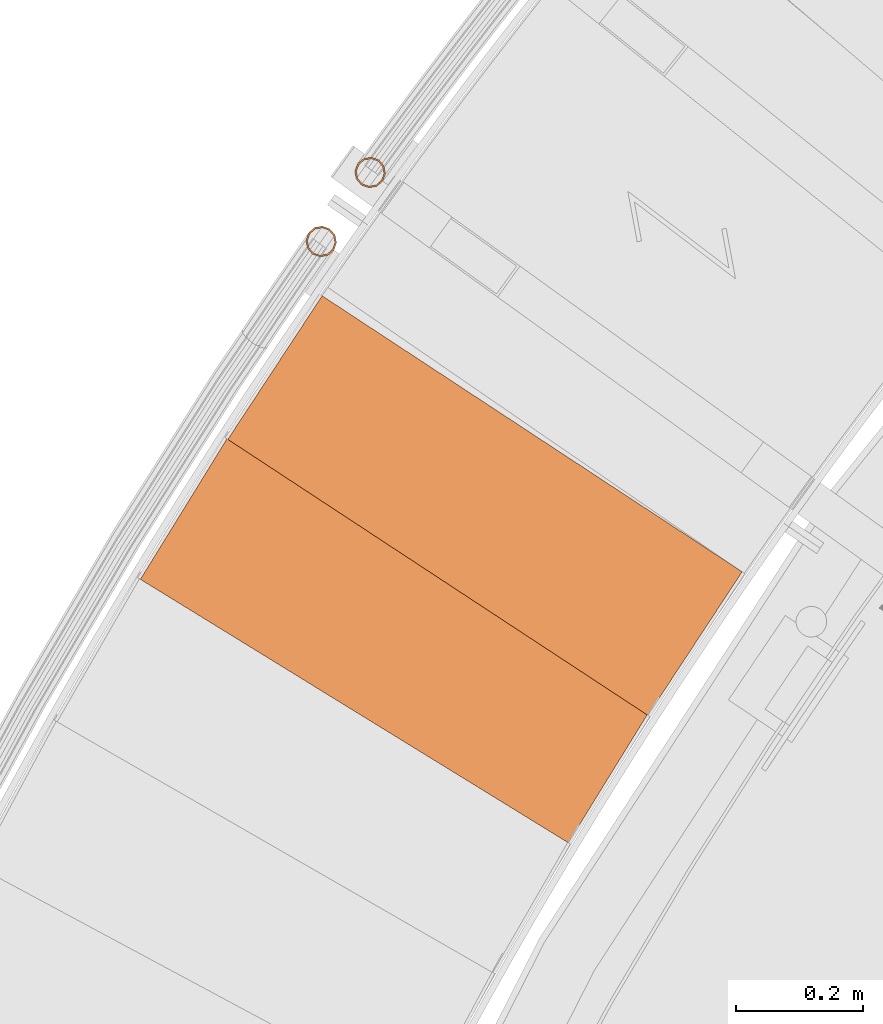
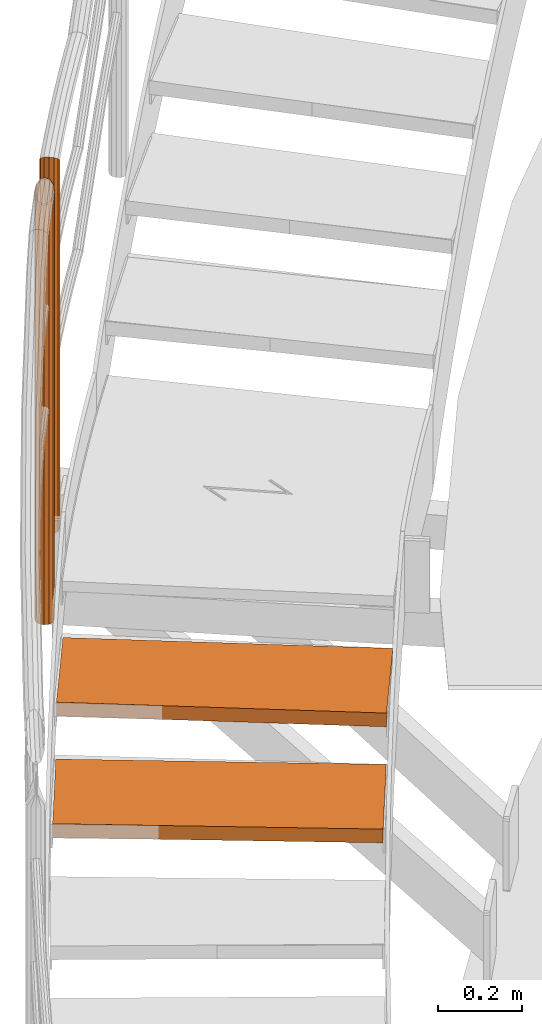
# One storey, part 30 of 126: 4 proxies.
"""IFC2X3 building model written with IfcOpenShell, lengths in millimetres."""

from ifc_helpers import new_model, si_unit, origin, origin_with_axes, place, context, project, spatial, faceted_brep, material, element, save


model = new_model("IFC2X3")

# Units and contexts
context_of_model_1 = context(None, 3, precision=0.1, world=origin())
context_of_model_2 = context(None, 3, precision=0.1, world=origin())
ifc_project = project(units=[si_unit("LENGTHUNIT", "METRE", prefix="MILLI"), si_unit("AREAUNIT", "SQUARE_METRE", prefix="CENTI"), si_unit("VOLUMEUNIT", "CUBIC_METRE", prefix="CENTI"), si_unit("MASSUNIT", "GRAM", prefix="KILO")], contexts=[context_of_model_1, context_of_model_2])

# Site, building, storey
site_placement = place(None, origin_with_axes())
site = spatial("IfcSite", under=ifc_project, at=site_placement, CompositionType="ELEMENT")
building_placement = place(site_placement, origin_with_axes())
building = spatial("IfcBuilding", under=site, at=building_placement, CompositionType="ELEMENT")
storey_placement = place(building_placement, origin_with_axes())
storey = spatial("IfcBuildingStorey", under=building, at=storey_placement, CompositionType="ELEMENT")

# Proxies
ifc_material = material(Name="S235JRG2")
proxy_1_placement = place(storey_placement, origin_with_axes())
element("IfcBuildingElementProxy", 1, at=proxy_1_placement, inside=storey, material=ifc_material, context=context_of_model_2, shape_type="Brep", body=[
    faceted_brep([(462.6859, 12561.818, 7926.89), (462.6859, 12561.818, 7966.89), (604.2286, 12791.743, 7966.89), (604.2286, 12791.743, 7926.89), (1135.4304, 12147.675, 7926.89), (1276.9731, 12377.6, 7926.89), (1276.9731, 12377.6, 7966.89), (1135.4304, 12147.675, 7966.89)], [[[0, 1, 2, 3]], [[4, 5, 6, 7]], [[0, 4, 7, 1]], [[1, 7, 6, 2]], [[2, 6, 5, 3]], [[3, 5, 4, 0]]]),
])
proxy_2_placement = place(storey_placement, origin_with_axes())
element("IfcBuildingElementProxy", 2, at=proxy_2_placement, inside=storey, material=ifc_material, context=context_of_model_2, shape_type="Brep", body=[
    faceted_brep([(600.0769, 12781.841, 8100.05), (600.0769, 12781.841, 8140.05), (748.3257, 13007.5, 8140.05), (748.3257, 13007.5, 8100.05), (1260.3402, 12348.075, 8100.05), (1408.5891, 12573.735, 8100.05), (1408.5891, 12573.735, 8140.05), (1260.3402, 12348.075, 8140.05)], [[[0, 1, 2, 3]], [[4, 5, 6, 7]], [[0, 4, 7, 1]], [[1, 7, 6, 2]], [[2, 6, 5, 3]], [[3, 5, 4, 0]]]),
])
proxy_3_placement = place(storey_placement, origin_with_axes())
element("IfcBuildingElementProxy", 3, at=proxy_3_placement, inside=storey, material=ifc_material, Name="HANDLAUF", context=context_of_model_2, shape_type="Brep", body=[
    faceted_brep([(760.3314, 13112.804, 8142.65), (748.4918, 13116.816, 8142.65), (748.4918, 13116.816, 9409.7746), (760.3314, 13112.804, 9413.3492), (768.5788, 13103.41, 9410.4852), (768.5788, 13103.41, 8142.65), (771.024, 13091.15, 9401.9499), (771.024, 13091.15, 8142.65), (767.0119, 13079.311, 9390.0304), (767.0119, 13079.311, 8142.65), (757.6175, 13071.063, 9377.9205), (757.6175, 13071.063, 8142.65), (745.358, 13068.618, 9368.8651), (745.358, 13068.618, 8142.65), (733.5184, 13072.63, 9365.2905), (733.5184, 13072.63, 8142.65), (725.271, 13082.025, 9368.1545), (725.271, 13082.025, 8142.65), (722.8258, 13094.284, 9376.6898), (722.8258, 13094.284, 8142.65), (726.8379, 13106.124, 9388.6093), (726.8379, 13106.124, 8142.65), (736.2323, 13114.371, 9400.7191), (736.2323, 13114.371, 8142.65), (737.3392, 13112.129, 8142.65), (748.3296, 13114.322, 8142.65), (748.3296, 13114.322, 9407.6571), (737.3392, 13112.129, 9399.5391), (728.9173, 13104.736, 9388.6828), (728.9173, 13104.736, 8142.65), (725.3205, 13094.122, 9377.9972), (725.3205, 13094.122, 8142.65), (727.5126, 13083.131, 9370.3455), (727.5126, 13083.131, 8142.65), (734.9062, 13074.71, 9367.778), (734.9062, 13074.71, 8142.65), (745.5202, 13071.113, 9370.9826), (745.5202, 13071.113, 8142.65), (756.5106, 13073.305, 9379.1006), (756.5106, 13073.305, 8142.65), (764.9325, 13080.698, 9389.9569), (764.9325, 13080.698, 8142.65), (768.5293, 13091.312, 9400.6425), (768.5293, 13091.312, 8142.65), (766.3372, 13102.303, 9408.2942), (766.3372, 13102.303, 8142.65), (758.9436, 13110.725, 9410.8617), (758.9436, 13110.725, 8142.65)], [[[0, 1, 2, 3]], [[0, 3, 4, 5]], [[5, 4, 6, 7]], [[7, 6, 8, 9]], [[9, 8, 10, 11]], [[11, 10, 12, 13]], [[13, 12, 14, 15]], [[15, 14, 16, 17]], [[17, 16, 18, 19]], [[19, 18, 20, 21]], [[21, 20, 22, 23]], [[1, 23, 22, 2]], [[24, 25, 26, 27]], [[24, 27, 28, 29]], [[29, 28, 30, 31]], [[31, 30, 32, 33]], [[33, 32, 34, 35]], [[35, 34, 36, 37]], [[37, 36, 38, 39]], [[39, 38, 40, 41]], [[41, 40, 42, 43]], [[43, 42, 44, 45]], [[45, 44, 46, 47]], [[25, 47, 46, 26]], [[19, 21, 23, 1, 0, 5, 7, 9, 11, 13, 15, 17], [24, 29, 31, 33, 35, 37, 39, 41, 43, 45, 47, 25]], [[14, 12, 10, 8, 6, 4, 3, 2, 22, 20, 18, 16], [26, 46, 44, 42, 40, 38, 36, 34, 32, 30, 28, 27]]]),
])
proxy_4_placement = place(storey_placement, origin_with_axes())
element("IfcBuildingElementProxy", 4, at=proxy_4_placement, inside=storey, material=ifc_material, Name="HANDLAUF", context=context_of_model_2, shape_type="Brep", body=[
    faceted_brep([(837.5591, 13221.256, 9365.55), (845.6795, 13211.752, 9368.7855), (845.6795, 13211.752, 8313.85), (837.5591, 13221.256, 8313.85), (847.9597, 13199.461, 9377.625), (847.9597, 13199.461, 8313.85), (843.7889, 13187.676, 9389.7), (843.7889, 13187.676, 8313.85), (834.2845, 13179.556, 9401.775), (834.2845, 13179.556, 8313.85), (821.9933, 13177.275, 9410.6145), (821.9933, 13177.275, 8313.85), (810.2086, 13181.446, 9413.85), (810.2086, 13181.446, 8313.85), (802.0882, 13190.951, 9410.6145), (802.0882, 13190.951, 8313.85), (799.808, 13203.242, 9401.775), (799.808, 13203.242, 8313.85), (803.9788, 13215.027, 9389.7), (803.9788, 13215.027, 8313.85), (813.4832, 13223.147, 9377.625), (813.4832, 13223.147, 8313.85), (825.7744, 13225.427, 9368.7855), (825.7744, 13225.427, 8313.85), (836.1434, 13219.196, 9368.05), (825.5787, 13222.935, 9370.9506), (825.5787, 13222.935, 8313.85), (836.1434, 13219.196, 8313.85), (814.5599, 13220.891, 9378.875), (814.5599, 13220.891, 8313.85), (806.0394, 13213.611, 9389.7), (806.0394, 13213.611, 8313.85), (802.3003, 13203.046, 9400.525), (802.3003, 13203.046, 8313.85), (804.3445, 13192.027, 9408.4495), (804.3445, 13192.027, 8313.85), (811.6243, 13183.507, 9411.35), (811.6243, 13183.507, 8313.85), (822.189, 13179.768, 9408.4495), (822.189, 13179.768, 8313.85), (833.2078, 13181.812, 9400.525), (833.2078, 13181.812, 8313.85), (841.7283, 13189.092, 9389.7), (841.7283, 13189.092, 8313.85), (845.4674, 13199.656, 9378.875), (845.4674, 13199.656, 8313.85), (843.4232, 13210.675, 9370.9506), (843.4232, 13210.675, 8313.85)], [[[0, 1, 2, 3]], [[1, 4, 5, 2]], [[4, 6, 7, 5]], [[6, 8, 9, 7]], [[8, 10, 11, 9]], [[10, 12, 13, 11]], [[12, 14, 15, 13]], [[14, 16, 17, 15]], [[16, 18, 19, 17]], [[18, 20, 21, 19]], [[20, 22, 23, 21]], [[0, 3, 23, 22]], [[24, 25, 26, 27]], [[25, 28, 29, 26]], [[28, 30, 31, 29]], [[30, 32, 33, 31]], [[32, 34, 35, 33]], [[34, 36, 37, 35]], [[36, 38, 39, 37]], [[38, 40, 41, 39]], [[40, 42, 43, 41]], [[42, 44, 45, 43]], [[44, 46, 47, 45]], [[24, 27, 47, 46]], [[18, 16, 14, 12, 10, 8, 6, 4, 1, 0, 22, 20], [24, 46, 44, 42, 40, 38, 36, 34, 32, 30, 28, 25]], [[19, 21, 23, 3, 2, 5, 7, 9, 11, 13, 15, 17], [26, 29, 31, 33, 35, 37, 39, 41, 43, 45, 47, 27]]]),
])

save(model, "model.ifc")
